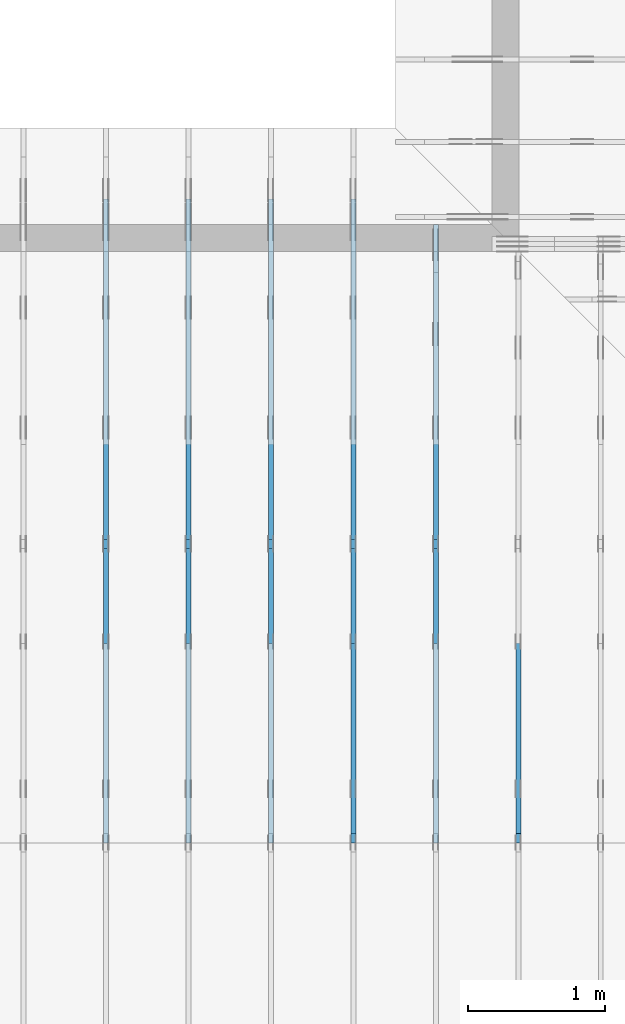
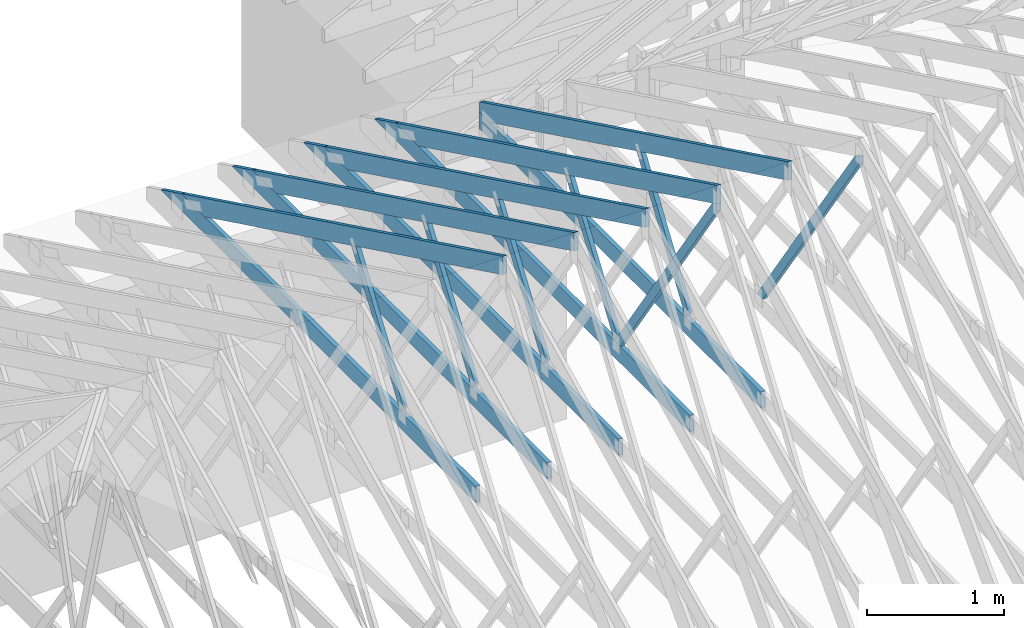
# One storey, part 16 of 159: 17 members, 6 elements without a shape of their own.
"""IFC2X3 building model written with IfcOpenShell, lengths in millimetres."""

from ifc_helpers import new_model, si_unit, frame, origin, origin_with_axes, origin_2d, place, context, project, spatial, faceted_brep, element, aggregate, save


model = new_model("IFC2X3")

# Units and contexts
model_context = context("Model", 3, precision=1e-05, world=origin())
plan_context = context("Plan", 2, precision=1e-05, world=origin_2d())
ifc_project = project(units=[si_unit("LENGTHUNIT", "METRE", prefix="MILLI"), si_unit("AREAUNIT", "SQUARE_METRE"), si_unit("VOLUMEUNIT", "CUBIC_METRE"), si_unit("SOLIDANGLEUNIT", "STERADIAN"), si_unit("PLANEANGLEUNIT", "RADIAN"), si_unit("MASSUNIT", "GRAM"), si_unit("TIMEUNIT", "SECOND"), si_unit("THERMODYNAMICTEMPERATUREUNIT", "DEGREE_CELSIUS"), si_unit("LUMINOUSINTENSITYUNIT", "LUMEN")], contexts=[model_context, plan_context])

# Site, building, storey
site_placement = place(None, origin_with_axes())
site = spatial("IfcSite", under=ifc_project, at=site_placement, CompositionType="ELEMENT")
building_placement = place(site_placement, origin_with_axes())
building = spatial("IfcBuilding", under=site, at=building_placement, Name="Plan 1", CompositionType="ELEMENT")
storey_placement = place(building_placement, origin_with_axes())
storey = spatial("IfcBuildingStorey", under=building, at=storey_placement, Name="Etasje 1", CompositionType="ELEMENT", Elevation=0.0)

# Assembly, member
assembly_1_placement = place(storey_placement, frame((10875.02226140475, -699.9989301294845, 1.1021457184401395e-15), z_axis=(-1.0, 1.836909530733566e-16, 6.123031769111886e-17), x_axis=(-1.836909530733566e-16, -1.0, 0.0)))
assembly_1 = element("IfcElementAssembly", 1, at=assembly_1_placement, inside=storey, Name="T4 (96)", AssemblyPlace="FACTORY", PredefinedType="TRUSS")
member_1_placement = place(assembly_1_placement, frame((-5230.134196319675, 2512.1392759871583, -36.0), z_axis=(0.0, 0.0, 1.0), x_axis=(-0.5642475050074617, -0.8256056886267528, 0.0)))
member_1 = element("IfcMember", 2, at=member_1_placement, Name="T4-D10", context=model_context, shape_type="Brep", body=[
    faceted_brep([(2543.5256108538483, 72.99999048793325, 36.0), (53.406771110820955, 72.99999048793325, 36.0), (0.0, 36.50009322373626, 36.0), (64.12142578860312, 0.00011835360965051223, 36.0), (2593.4163311647717, 0.00011835360965051223, 36.0), (53.406771110820955, 72.99999048793325, 6.5402271239448724e-15), (2543.5256108538483, 72.99999048793325, 3.114817624161566e-13), (2593.4163311647717, 0.00011835360965051223, 3.175914117251098e-13), (64.12142578860312, 0.00011835360965051223, 7.852350543687342e-15), (0.0, 36.50009322373626, 0.0), (3.72532881449672e-05, 36.50017519275116, 3.944304526105059e-31), (3.72532881449672e-05, 36.50017519275116, 36.0), (53.40675570041866, 73.00017519218363, 36.0), (53.40675570041866, 73.00017519218363, 7.888609052210118e-31), (64.12144158709383, 0.00017519218362238576, 7.888609052210118e-31), (64.12144158709383, 0.00017519218362593847, 36.0), (3.7253288159178055e-05, 36.500175192751165, 36.0), (3.72532881574017e-05, 36.500175192751165, -3.944304526105059e-31), (2593.4162114323694, 0.0001751921831566568, 2.916933296842317e-29), (2593.4162114323694, 0.00017519218315886108, 36.0), (64.12144158709384, 0.00017519218362346966, 36.0), (64.12144158709384, 0.00017519218362126537, 7.212035881277958e-31), (2543.52548462057, 73.00017519218363, -8.473528143218631e-30), (2543.52548462057, 73.00017519218363, 36.0), (2593.41621143237, 0.00017519218386041757, 36.0), (2593.41621143237, 0.00017519218386041757, -9.018458054926462e-30), (53.40675570041867, 73.00017519218363, 0.0), (53.40675570041867, 73.00017519218363, 36.0), (2543.52548462057, 73.00017519218348, 36.0), (2543.52548462057, 73.00017519218348, -9.466330862652142e-30)], [[[0, 1, 2, 3, 4]], [[5, 6, 7, 8, 9]], [[10, 11, 12, 13]], [[14, 15, 16, 17]], [[18, 19, 20, 21]], [[22, 23, 24, 25]], [[26, 27, 28, 29]]]),
])
aggregate(assembly_1, [member_1])

# Assembly, members
assembly_2_placement = place(storey_placement, frame((10275.02226140475, -699.9989301294845, 1.1021457184401395e-15), z_axis=(-1.0, 1.836909530733566e-16, 6.123031769111886e-17), x_axis=(-1.836909530733566e-16, -1.0, 0.0)))
assembly_2 = element("IfcElementAssembly", 3, at=assembly_2_placement, inside=storey, Name="T3 (95)", AssemblyPlace="FACTORY", PredefinedType="TRUSS")
member_2_placement = place(assembly_2_placement, frame((-9670.743129899618, 311.0165290904456, -36.0), z_axis=(0.0, 0.0, 1.0), x_axis=(0.898794046299167, 0.4383711467890774, 0.0)))
member_2 = element("IfcMember", 4, at=member_2_placement, Name="T3-O6", context=model_context, shape_type="Brep", body=[
    faceted_brep([(5046.342559639348, 148.00022876572712, 36.0), (39.63434100887753, 148.00022876572712, 36.0), (0.0, 66.73772613040637, 36.0), (136.8326162634403, 0.00027202273213333683, 36.0), (4974.158157629452, 0.00027202273213333683, 36.0), (39.63434100887753, 148.00016775937365, 4.853646582903423e-15), (5046.342559639348, 148.00016775937365, 6.179783162098624e-13), (4974.158157629452, 0.00027202273213333683, 6.091385684750437e-13), (136.8326162634403, 0.00027202273213333683, 1.6756609128634812e-14), (0.0, 66.73772613040637, 0.0), (39.63443079568788, 148.0001389979634, -1.5777218104420236e-30), (39.63443079568788, 148.0001389979634, 36.0), (5046.342588912216, 148.00018235817603, 36.0), (5046.342588912216, 148.00018235817603, -4.733165431326071e-30), (8.386469560761611e-05, 66.7376852268617, 1.5777218104420236e-30), (8.386469561116883e-05, 66.7376852268617, 36.0), (39.63443079568785, 148.00013899796346, 36.0), (39.63443079568785, 148.00013899796346, 2.7610131682735413e-30), (136.8323349366292, 0.00013721225329987874, 1.5777218104420236e-30), (136.8323349366292, 0.00013721225329987874, 36.0), (8.386469562537968e-05, 66.73768522686169, 36.0), (8.386469562537968e-05, 66.73768522686169, 0.0), (4974.158165804005, 0.00018235721913755211, 2.310725526200097e-28), (4974.158165804005, 0.0001823572191397564, 36.0), (136.8323349366292, 0.00013721225321958647, 36.0), (136.8323349366292, 0.00013721225321738218, 6.356494165630846e-30), (5046.342588912216, 148.00018235817538, 1.082008787315909e-28), (5046.342588912216, 148.00018235817538, 36.0), (4974.158165804005, 0.00018235722245663055, 36.0), (4974.158165804005, 0.00018235722245663055, 1.0769346525604365e-28)], [[[0, 1, 2, 3, 4]], [[5, 6, 7, 8, 9]], [[10, 11, 12, 13]], [[14, 15, 16, 17]], [[18, 19, 20, 21]], [[22, 23, 24, 25]], [[26, 27, 28, 29]]]),
])
member_3_placement = place(assembly_2_placement, frame((-5591.18115234375, 371.0000000000005, -36.0), z_axis=(0.0, 0.0, 1.0), x_axis=(-1.0, 1.2246063538223773e-16, 0.0)))
member_3 = element("IfcMember", 5, at=member_3_placement, Name="T3-U36", context=model_context, shape_type="Brep", body=[
    faceted_brep([(4108.81787109375, 148.00000000000102, 36.0), (0.0, 148.00000000000102, 36.0), (0.0, 5.115907697472721e-13, 36.0), (4108.81787109375, 5.115907697472721e-13, 36.0), (0.0, 148.00000000000102, 0.0), (4108.81787109375, 148.00000000000102, 5.03168447164034e-13), (4108.81787109375, 5.115907697472721e-13, 5.03168447164034e-13), (0.0, 5.115907697472721e-13, 0.0), (0.00014333892431750428, 0.0, 0.0), (0.00014333892431970857, -2.6993892992798474e-31, 36.0), (0.00014333892433783274, 147.99999999999997, 36.0), (0.00014333892433562845, 147.99999999999997, -1.1097494219785373e-30), (4108.817777785727, -7.547526893006019e-13, 1.088634776630412e-28), (4108.817777785727, -7.525483978637216e-13, 36.0), (0.00014333892431750428, 2.2042294124261307e-15, 36.0), (0.00014333892431750428, -6.202445414848912e-20, 3.797777032130224e-36), (4108.817777785727, 148.00000000000102, 0.0), (4108.817777785727, 148.00000000000102, 36.0), (4108.817777785727, 1.0231815394945443e-12, 36.0), (4108.817777785727, 1.0231815394945443e-12, 0.0), (0.00014333892431750428, 147.99999999999997, 0.0), (0.00014333892431750428, 147.99999999999997, 36.0), (4108.817777785727, 148.00000000000063, 36.0), (4108.817777785727, 148.00000000000063, -2.3665827156630354e-29)], [[[0, 1, 2, 3]], [[4, 5, 6, 7]], [[8, 9, 10, 11]], [[12, 13, 14, 15]], [[16, 17, 18, 19]], [[20, 21, 22, 23]]]),
])
member_4_placement = place(assembly_2_placement, frame((-7407.03675845016, 1415.1000747842745, -36.0), z_axis=(0.0, 0.0, 1.0), x_axis=(0.5642475146587648, -0.825605682030718, 0.0)))
member_4 = element("IfcMember", 6, at=member_4_placement, Name="T3-D42", context=model_context, shape_type="Brep", body=[
    faceted_brep([(1236.1861515968458, 73.00016783019692, 36.0), (10.714714150930376, 73.00016783019692, 36.0), (5.8619780247681774e-05, 0.00012630768742383225, 36.0), (1264.6475113078654, 0.00012630768742383225, 36.0), (10.714714150930376, 73.00016783019692, 1.3121307028619877e-15), (1236.1861515968458, 73.00016783019692, 1.5138414157527298e-13), (1264.6475113078654, 0.00012630768742383225, 1.5486953776932687e-13), (5.8619780247681774e-05, 0.00012630768742383225, 7.178615535098259e-21), (-5.169199835945012e-16, 1.8190652752628798e-12, 3.199029423154123e-32), (1.6640044277278812e-15, 1.8187451667643957e-12, 36.0), (10.71468606065991, 73.00000000000276, 36.0), (10.714686060659908, 73.00000000000276, 6.262642696661222e-31), (1264.6473946450233, -6.597799305856201e-13, 4.039853475598186e-29), (1264.6473946450233, -6.575756391487398e-13, 36.0), (4.320516564825666e-30, 1.8211936949827368e-12, 36.0), (0.0, 1.8189894035458565e-12, 0.0), (1236.1860387301315, 73.00000000000097, 1.262177448353619e-29), (1236.1860387301315, 73.00000000000097, 36.0), (1264.6473946450235, 5.684341886080802e-14, 36.0), (1264.6473946450235, 5.684341886080802e-14, 1.262177448353619e-29), (10.714686060659915, 73.00000000000273, 0.0), (10.714686060659915, 73.00000000000273, 36.0), (1236.1860387301313, 73.0000000000013, 36.0), (1236.1860387301313, 73.0000000000013, 2.3665827156630354e-29)], [[[0, 1, 2, 3]], [[4, 5, 6, 7]], [[8, 9, 10, 11]], [[12, 13, 14, 15]], [[16, 17, 18, 19]], [[20, 21, 22, 23]]]),
])
aggregate(assembly_2, [member_2, member_3, member_4])

assembly_3_placement = place(storey_placement, frame((9675.022261404752, 9699.99999999999, 1.1021457184401395e-15), z_axis=(-1.0, 1.836909530733566e-16, 6.123031769111886e-17), x_axis=(-1.836909530733566e-16, -1.0, 0.0)))
assembly_3 = element("IfcElementAssembly", 7, at=assembly_3_placement, inside=storey, Name="T2 (94)", AssemblyPlace="FACTORY", PredefinedType="TRUSS")
member_5_placement = place(assembly_3_placement, frame((579.5051980003889, 237.97847286708455, -36.00000000000001), z_axis=(0.0, 0.0, 1.0), x_axis=(0.8987940462991671, 0.43837114678907757, 0.0)))
member_5 = element("IfcMember", 8, at=member_5_placement, Name="T2-O3", context=model_context, shape_type="Brep", body=[
    faceted_brep([(5212.955369683486, 148.00001471731446, 36.0), (1.573016606926103e-05, 148.00001471731446, 36.0), (303.44498744329735, 0.0, 36.0), (5140.770967673589, 0.0, 36.0), (1.573016606926103e-05, 148.00001471731446, 1.9263261315098228e-21), (5212.955369683486, 148.00001471731446, 6.383818267906877e-13), (5140.770967673589, 0.0, 6.295420790558688e-13), (303.44498744329735, 0.0, 3.716006596586134e-14), (303.44496855236554, 9.213724169399029e-06, 8.404281481000962e-31), (303.44496855236554, 9.213724169399029e-06, 36.0), (0.0, 148.000009213056, 36.0), (0.0, 148.000009213056, -1.9992365007213114e-31), (5140.770891984262, 9.214032787493993e-06, -1.5668329852774188e-28), (5140.770891984262, 9.214032789698284e-06, 36.0), (303.4449685523656, 9.213724336859708e-06, 36.0), (303.4449685523656, 9.213724334655416e-06, -9.24856583218491e-30), (5212.955315091657, 148.00000921330889, -5.793884668474286e-29), (5212.955315091657, 148.00000921330889, 36.0), (5140.770891984262, 9.214030342263868e-06, 36.0), (5140.770891984262, 9.214030342263868e-06, -5.743143320920135e-29), (0.0, 148.000009213056, 0.0), (0.0, 148.000009213056, 36.0), (5212.955315091657, 148.00000921330917, 36.0), (5212.955315091657, 148.00000921330917, 9.466330862652142e-30)], [[[0, 1, 2, 3]], [[4, 5, 6, 7]], [[8, 9, 10, 11]], [[12, 13, 14, 15]], [[16, 17, 18, 19]], [[20, 21, 22, 23]]]),
])
member_6_placement = place(assembly_3_placement, frame((4808.81787109375, 371.0000000000005, -36.0), z_axis=(0.0, 0.0, 1.0), x_axis=(-1.0, 1.2246063538223773e-16, 0.0)))
member_6 = element("IfcMember", 9, at=member_6_placement, Name="T2-U35", context=model_context, shape_type="Brep", body=[
    faceted_brep([(4597.636581420898, 148.00000000000105, 36.0), (0.0, 148.00000000000105, 36.0), (0.0, 5.115907697472721e-13, 36.0), (4294.191589355469, 5.115907697472721e-13, 36.0), (0.0, 148.00000000000105, 0.0), (4597.636581420898, 148.00000000000105, 5.630294970174226e-13), (4294.191589355469, 5.115907697472721e-13, 5.25869430485532e-13), (0.0, 5.115907697472721e-13, 0.0), (0.00023664694708713796, 0.0, 0.0), (0.00023664694708934225, -2.6993892992798474e-31, 36.0), (0.00023664694710746643, 147.99999999999994, 36.0), (0.00023664694710526213, 147.99999999999994, -1.1097479173457682e-30), (4294.191606856883, -7.888042053292689e-13, 1.1094846280734072e-28), (4294.191606856883, -7.865999138923886e-13, 36.0), (0.00023664694708713796, 2.2041915808575547e-15, 36.0), (0.00023664694708713796, -9.985602272457245e-20, 6.114215994797155e-36), (4597.636575412006, 148.00000000000205, -2.5243548967072372e-29), (4597.636575412006, 148.00000000000205, 36.0), (4294.191606856883, 1.5916157281026244e-12, 36.0), (4294.191606856883, 1.5916157281026244e-12, -2.5243548967072372e-29), (0.00023664694708713796, 147.99999999999994, 0.0), (0.00023664694708713796, 147.99999999999994, 36.0), (4597.636575412005, 148.00000000000068, 36.0), (4597.636575412005, 148.00000000000068, -2.208810534618833e-29)], [[[0, 1, 2, 3]], [[4, 5, 6, 7]], [[8, 9, 10, 11]], [[12, 13, 14, 15]], [[16, 17, 18, 19]], [[20, 21, 22, 23]]]),
])
member_7_placement = place(assembly_3_placement, frame((5169.864827117615, 2512.139275987297, -36.0), z_axis=(0.0, 0.0, 1.0), x_axis=(-0.564247505007381, -0.8256056886268078, 0.0)))
member_7 = element("IfcMember", 10, at=member_7_placement, Name="T2-D10", context=model_context, shape_type="Brep", body=[
    faceted_brep([(2543.525473098112, 73.00019205182707, 36.0), (53.406771110823684, 73.00019205182707, 36.0), (0.0, 36.5000932239891, 36.0), (64.12142578859857, 0.00011835385657832376, 36.0), (2593.4163311647667, 0.00011835385657832376, 36.0), (53.406771110823684, 73.00019205182707, 6.540227123945206e-15), (2543.525473098112, 73.00019205182707, 3.114817455465016e-13), (2593.4163311647667, 0.00011835385657832376, 3.175914117251092e-13), (64.12142578859857, 0.00011835385657832376, 7.852350543686785e-15), (0.0, 36.5000932239891, 0.0), (8.990056994662154e-05, 36.50009815631665, 3.944304526105059e-31), (8.990056994662154e-05, 36.50009815631665, 36.0), (53.40680834923387, 73.00009815680099, 36.0), (53.40680834923387, 73.00009815680099, 7.888609052210118e-31), (64.12149423256596, 9.815680185809583e-05, 6.171430365172586e-31), (64.12149423256596, 9.815680186164855e-05, 36.0), (8.990056995195062e-05, 36.50009815631667, 36.0), (8.990056995017426e-05, 36.50009815631666, -3.3878954237129854e-31), (2593.4162640810096, 9.815680364966906e-05, 2.3313020864942917e-30), (2593.4162640810096, 9.815680365187335e-05, 36.0), (64.12149423256596, 9.815680187001689e-05, 36.0), (64.12149423256596, 9.81568018678126e-05, 5.76409767496333e-32), (2543.5255372692222, 73.00009815680278, 0.0), (2543.5255372692222, 73.00009815680278, 36.0), (2593.4162640810096, 9.815680414249073e-05, 36.0), (2593.4162640810096, 9.815680414249073e-05, 0.0), (53.40680834923387, 73.00009815680097, 7.888609052210118e-31), (53.40680834923387, 73.00009815680097, 36.0), (2543.525537269222, 73.00009815680359, 36.0), (2543.525537269222, 73.00009815680359, 4.9698237028923744e-29)], [[[0, 1, 2, 3, 4]], [[5, 6, 7, 8, 9]], [[10, 11, 12, 13]], [[14, 15, 16, 17]], [[18, 19, 20, 21]], [[22, 23, 24, 25]], [[26, 27, 28, 29]]]),
])
member_8_placement = place(assembly_3_placement, frame((2992.962039007774, 1415.1000197155186, -36.0), z_axis=(0.0, 0.0, 1.0), x_axis=(0.5642475050068997, -0.8256056886271368, 0.0)))
member_8 = element("IfcMember", 11, at=member_8_placement, Name="T2-D42", context=model_context, shape_type="Brep", body=[
    faceted_brep([(1236.1860950310158, 73.0001983605489, 36.0), (10.714657585100667, 73.0001983605489, 36.0), (2.9073682981106685e-06, 0.00014238622361517628, 36.0), (1264.647317839714, 0.00014238622361517628, 36.0), (10.714657585100667, 73.0001983605489, 1.3121237757745405e-15), (1236.1860950310158, 73.0001983605489, 1.513841346481855e-13), (1264.647317839714, 0.00014238622361517628, 1.5486951407709413e-13), (2.9073682981106685e-06, 0.00014238622361517628, 3.560381690768076e-22), (-1.0876495965808294e-15, 9.815680186891362e-05, 6.73106873190455e-32), (1.0932755894164925e-15, 9.815680186859351e-05, 36.0), (10.71468588481117, 73.00009815680141, 36.0), (10.714685884811168, 73.00009815680141, -5.004528960490232e-31), (1264.6473849234712, 9.81568027596822e-05, 5.682548008281813e-29), (1264.6473849234712, 9.815680276188649e-05, 36.0), (-1.5529013882837331e-30, 9.815680187095826e-05, 36.0), (0.0, 9.815680186875397e-05, 0.0), (1236.1860298813824, 73.00009815680414, 0.0), (1236.1860298813824, 73.00009815680414, 36.0), (1264.6473849234712, 9.81568037445868e-05, 36.0), (1264.6473849234712, 9.81568037445868e-05, 1.262177448353619e-29), (10.714685884811162, 73.00009815680141, 0.0), (10.714685884811162, 73.0000981568014, 36.0), (1236.1860298813824, 73.00009815680406, 36.0), (1236.1860298813824, 73.00009815680406, -5.5220263365470826e-30)], [[[0, 1, 2, 3]], [[4, 5, 6, 7]], [[8, 9, 10, 11]], [[12, 13, 14, 15]], [[16, 17, 18, 19]], [[20, 21, 22, 23]]]),
])
aggregate(assembly_3, [member_5, member_6, member_7, member_8])

assembly_4_placement = place(storey_placement, frame((9075.022261404752, 9699.99999999999, 1.1021457184401395e-15), z_axis=(-1.0, 1.836909530733566e-16, 6.123031769111886e-17), x_axis=(-1.836909530733566e-16, -1.0, 0.0)))
assembly_4 = element("IfcElementAssembly", 12, at=assembly_4_placement, inside=storey, Name="T2 (93)", AssemblyPlace="FACTORY", PredefinedType="TRUSS")
member_9_placement = place(assembly_4_placement, frame((579.5051980003889, 237.97847286708455, -36.00000000000001), z_axis=(0.0, 0.0, 1.0), x_axis=(0.8987940462991671, 0.43837114678907757, 0.0)))
member_9 = element("IfcMember", 13, at=member_9_placement, Name="T2-O3", context=model_context, shape_type="Brep", body=[
    faceted_brep([(5212.955369683486, 148.00001471731446, 36.0), (1.573016606926103e-05, 148.00001471731446, 36.0), (303.44498744329735, 0.0, 36.0), (5140.770967673589, 0.0, 36.0), (1.573016606926103e-05, 148.00001471731446, 1.9263261315098228e-21), (5212.955369683486, 148.00001471731446, 6.383818267906877e-13), (5140.770967673589, 0.0, 6.295420790558688e-13), (303.44498744329735, 0.0, 3.716006596586134e-14), (303.44496855236554, 9.213724169399029e-06, 8.404281481000962e-31), (303.44496855236554, 9.213724169399029e-06, 36.0), (0.0, 148.000009213056, 36.0), (0.0, 148.000009213056, -1.9992365007213114e-31), (5140.770891984262, 9.214032787493993e-06, -1.5668329852774188e-28), (5140.770891984262, 9.214032789698284e-06, 36.0), (303.4449685523656, 9.213724336859708e-06, 36.0), (303.4449685523656, 9.213724334655416e-06, -9.24856583218491e-30), (5212.955315091657, 148.00000921330889, -5.793884668474286e-29), (5212.955315091657, 148.00000921330889, 36.0), (5140.770891984262, 9.214030342263868e-06, 36.0), (5140.770891984262, 9.214030342263868e-06, -5.743143320920135e-29), (0.0, 148.000009213056, 0.0), (0.0, 148.000009213056, 36.0), (5212.955315091657, 148.00000921330917, 36.0), (5212.955315091657, 148.00000921330917, 9.466330862652142e-30)], [[[0, 1, 2, 3]], [[4, 5, 6, 7]], [[8, 9, 10, 11]], [[12, 13, 14, 15]], [[16, 17, 18, 19]], [[20, 21, 22, 23]]]),
])
member_10_placement = place(assembly_4_placement, frame((4808.81787109375, 371.0000000000005, -36.0), z_axis=(0.0, 0.0, 1.0), x_axis=(-1.0, 1.2246063538223773e-16, 0.0)))
member_10 = element("IfcMember", 14, at=member_10_placement, Name="T2-U35", context=model_context, shape_type="Brep", body=[
    faceted_brep([(4597.636581420898, 148.00000000000105, 36.0), (0.0, 148.00000000000105, 36.0), (0.0, 5.115907697472721e-13, 36.0), (4294.191589355469, 5.115907697472721e-13, 36.0), (0.0, 148.00000000000105, 0.0), (4597.636581420898, 148.00000000000105, 5.630294970174226e-13), (4294.191589355469, 5.115907697472721e-13, 5.25869430485532e-13), (0.0, 5.115907697472721e-13, 0.0), (0.00023664694708713796, 0.0, 0.0), (0.00023664694708934225, -2.6993892992798474e-31, 36.0), (0.00023664694710746643, 147.99999999999994, 36.0), (0.00023664694710526213, 147.99999999999994, -1.1097479173457682e-30), (4294.191606856883, -7.888042053292689e-13, 1.1094846280734072e-28), (4294.191606856883, -7.865999138923886e-13, 36.0), (0.00023664694708713796, 2.2041915808575547e-15, 36.0), (0.00023664694708713796, -9.985602272457245e-20, 6.114215994797155e-36), (4597.636575412006, 148.00000000000205, -2.5243548967072372e-29), (4597.636575412006, 148.00000000000205, 36.0), (4294.191606856883, 1.5916157281026244e-12, 36.0), (4294.191606856883, 1.5916157281026244e-12, -2.5243548967072372e-29), (0.00023664694708713796, 147.99999999999994, 0.0), (0.00023664694708713796, 147.99999999999994, 36.0), (4597.636575412005, 148.00000000000068, 36.0), (4597.636575412005, 148.00000000000068, -2.208810534618833e-29)], [[[0, 1, 2, 3]], [[4, 5, 6, 7]], [[8, 9, 10, 11]], [[12, 13, 14, 15]], [[16, 17, 18, 19]], [[20, 21, 22, 23]]]),
])
member_11_placement = place(assembly_4_placement, frame((2992.962039007774, 1415.1000197155186, -36.0), z_axis=(0.0, 0.0, 1.0), x_axis=(0.5642475050068997, -0.8256056886271368, 0.0)))
member_11 = element("IfcMember", 15, at=member_11_placement, Name="T2-D42", context=model_context, shape_type="Brep", body=[
    faceted_brep([(1236.1860950310158, 73.0001983605489, 36.0), (10.714657585100667, 73.0001983605489, 36.0), (2.9073682981106685e-06, 0.00014238622361517628, 36.0), (1264.647317839714, 0.00014238622361517628, 36.0), (10.714657585100667, 73.0001983605489, 1.3121237757745405e-15), (1236.1860950310158, 73.0001983605489, 1.513841346481855e-13), (1264.647317839714, 0.00014238622361517628, 1.5486951407709413e-13), (2.9073682981106685e-06, 0.00014238622361517628, 3.560381690768076e-22), (-1.0876495965808294e-15, 9.815680186891362e-05, 6.73106873190455e-32), (1.0932755894164925e-15, 9.815680186859351e-05, 36.0), (10.71468588481117, 73.00009815680141, 36.0), (10.714685884811168, 73.00009815680141, -5.004528960490232e-31), (1264.6473849234712, 9.81568027596822e-05, 5.682548008281813e-29), (1264.6473849234712, 9.815680276188649e-05, 36.0), (-1.5529013882837331e-30, 9.815680187095826e-05, 36.0), (0.0, 9.815680186875397e-05, 0.0), (1236.1860298813824, 73.00009815680414, 0.0), (1236.1860298813824, 73.00009815680414, 36.0), (1264.6473849234712, 9.81568037445868e-05, 36.0), (1264.6473849234712, 9.81568037445868e-05, 1.262177448353619e-29), (10.714685884811162, 73.00009815680141, 0.0), (10.714685884811162, 73.0000981568014, 36.0), (1236.1860298813824, 73.00009815680406, 36.0), (1236.1860298813824, 73.00009815680406, -5.5220263365470826e-30)], [[[0, 1, 2, 3]], [[4, 5, 6, 7]], [[8, 9, 10, 11]], [[12, 13, 14, 15]], [[16, 17, 18, 19]], [[20, 21, 22, 23]]]),
])
aggregate(assembly_4, [member_9, member_10, member_11])

assembly_5_placement = place(storey_placement, frame((8475.022261404752, 9699.99999999999, 1.1021457184401395e-15), z_axis=(-1.0, 1.836909530733566e-16, 6.123031769111886e-17), x_axis=(-1.836909530733566e-16, -1.0, 0.0)))
assembly_5 = element("IfcElementAssembly", 16, at=assembly_5_placement, inside=storey, Name="T2 (92)", AssemblyPlace="FACTORY", PredefinedType="TRUSS")
member_12_placement = place(assembly_5_placement, frame((579.5051980003889, 237.97847286708455, -36.00000000000001), z_axis=(0.0, 0.0, 1.0), x_axis=(0.8987940462991671, 0.43837114678907757, 0.0)))
member_12 = element("IfcMember", 17, at=member_12_placement, Name="T2-O3", context=model_context, shape_type="Brep", body=[
    faceted_brep([(5212.955369683486, 148.00001471731446, 36.0), (1.573016606926103e-05, 148.00001471731446, 36.0), (303.44498744329735, 0.0, 36.0), (5140.770967673589, 0.0, 36.0), (1.573016606926103e-05, 148.00001471731446, 1.9263261315098228e-21), (5212.955369683486, 148.00001471731446, 6.383818267906877e-13), (5140.770967673589, 0.0, 6.295420790558688e-13), (303.44498744329735, 0.0, 3.716006596586134e-14), (303.44496855236554, 9.213724169399029e-06, 8.404281481000962e-31), (303.44496855236554, 9.213724169399029e-06, 36.0), (0.0, 148.000009213056, 36.0), (0.0, 148.000009213056, -1.9992365007213114e-31), (5140.770891984262, 9.214032787493993e-06, -1.5668329852774188e-28), (5140.770891984262, 9.214032789698284e-06, 36.0), (303.4449685523656, 9.213724336859708e-06, 36.0), (303.4449685523656, 9.213724334655416e-06, -9.24856583218491e-30), (5212.955315091657, 148.00000921330889, -5.793884668474286e-29), (5212.955315091657, 148.00000921330889, 36.0), (5140.770891984262, 9.214030342263868e-06, 36.0), (5140.770891984262, 9.214030342263868e-06, -5.743143320920135e-29), (0.0, 148.000009213056, 0.0), (0.0, 148.000009213056, 36.0), (5212.955315091657, 148.00000921330917, 36.0), (5212.955315091657, 148.00000921330917, 9.466330862652142e-30)], [[[0, 1, 2, 3]], [[4, 5, 6, 7]], [[8, 9, 10, 11]], [[12, 13, 14, 15]], [[16, 17, 18, 19]], [[20, 21, 22, 23]]]),
])
member_13_placement = place(assembly_5_placement, frame((4808.81787109375, 371.0000000000005, -36.0), z_axis=(0.0, 0.0, 1.0), x_axis=(-1.0, 1.2246063538223773e-16, 0.0)))
member_13 = element("IfcMember", 18, at=member_13_placement, Name="T2-U35", context=model_context, shape_type="Brep", body=[
    faceted_brep([(4597.636581420898, 148.00000000000105, 36.0), (0.0, 148.00000000000105, 36.0), (0.0, 5.115907697472721e-13, 36.0), (4294.191589355469, 5.115907697472721e-13, 36.0), (0.0, 148.00000000000105, 0.0), (4597.636581420898, 148.00000000000105, 5.630294970174226e-13), (4294.191589355469, 5.115907697472721e-13, 5.25869430485532e-13), (0.0, 5.115907697472721e-13, 0.0), (0.00023664694708713796, 0.0, 0.0), (0.00023664694708934225, -2.6993892992798474e-31, 36.0), (0.00023664694710746643, 147.99999999999994, 36.0), (0.00023664694710526213, 147.99999999999994, -1.1097479173457682e-30), (4294.191606856883, -7.888042053292689e-13, 1.1094846280734072e-28), (4294.191606856883, -7.865999138923886e-13, 36.0), (0.00023664694708713796, 2.2041915808575547e-15, 36.0), (0.00023664694708713796, -9.985602272457245e-20, 6.114215994797155e-36), (4597.636575412006, 148.00000000000205, -2.5243548967072372e-29), (4597.636575412006, 148.00000000000205, 36.0), (4294.191606856883, 1.5916157281026244e-12, 36.0), (4294.191606856883, 1.5916157281026244e-12, -2.5243548967072372e-29), (0.00023664694708713796, 147.99999999999994, 0.0), (0.00023664694708713796, 147.99999999999994, 36.0), (4597.636575412005, 148.00000000000068, 36.0), (4597.636575412005, 148.00000000000068, -2.208810534618833e-29)], [[[0, 1, 2, 3]], [[4, 5, 6, 7]], [[8, 9, 10, 11]], [[12, 13, 14, 15]], [[16, 17, 18, 19]], [[20, 21, 22, 23]]]),
])
member_14_placement = place(assembly_5_placement, frame((2992.962039007774, 1415.1000197155186, -36.0), z_axis=(0.0, 0.0, 1.0), x_axis=(0.5642475050068997, -0.8256056886271368, 0.0)))
member_14 = element("IfcMember", 19, at=member_14_placement, Name="T2-D42", context=model_context, shape_type="Brep", body=[
    faceted_brep([(1236.1860950310158, 73.0001983605489, 36.0), (10.714657585100667, 73.0001983605489, 36.0), (2.9073682981106685e-06, 0.00014238622361517628, 36.0), (1264.647317839714, 0.00014238622361517628, 36.0), (10.714657585100667, 73.0001983605489, 1.3121237757745405e-15), (1236.1860950310158, 73.0001983605489, 1.513841346481855e-13), (1264.647317839714, 0.00014238622361517628, 1.5486951407709413e-13), (2.9073682981106685e-06, 0.00014238622361517628, 3.560381690768076e-22), (-1.0876495965808294e-15, 9.815680186891362e-05, 6.73106873190455e-32), (1.0932755894164925e-15, 9.815680186859351e-05, 36.0), (10.71468588481117, 73.00009815680141, 36.0), (10.714685884811168, 73.00009815680141, -5.004528960490232e-31), (1264.6473849234712, 9.81568027596822e-05, 5.682548008281813e-29), (1264.6473849234712, 9.815680276188649e-05, 36.0), (-1.5529013882837331e-30, 9.815680187095826e-05, 36.0), (0.0, 9.815680186875397e-05, 0.0), (1236.1860298813824, 73.00009815680414, 0.0), (1236.1860298813824, 73.00009815680414, 36.0), (1264.6473849234712, 9.81568037445868e-05, 36.0), (1264.6473849234712, 9.81568037445868e-05, 1.262177448353619e-29), (10.714685884811162, 73.00009815680141, 0.0), (10.714685884811162, 73.0000981568014, 36.0), (1236.1860298813824, 73.00009815680406, 36.0), (1236.1860298813824, 73.00009815680406, -5.5220263365470826e-30)], [[[0, 1, 2, 3]], [[4, 5, 6, 7]], [[8, 9, 10, 11]], [[12, 13, 14, 15]], [[16, 17, 18, 19]], [[20, 21, 22, 23]]]),
])
aggregate(assembly_5, [member_12, member_13, member_14])

assembly_6_placement = place(storey_placement, frame((7875.0222614047525, 9699.99999999999, 1.1021457184401395e-15), z_axis=(-1.0, 1.836909530733566e-16, 6.123031769111886e-17), x_axis=(-1.836909530733566e-16, -1.0, 0.0)))
assembly_6 = element("IfcElementAssembly", 20, at=assembly_6_placement, inside=storey, Name="T2 (91)", AssemblyPlace="FACTORY", PredefinedType="TRUSS")
member_15_placement = place(assembly_6_placement, frame((579.5051980003889, 237.97847286708455, -36.00000000000001), z_axis=(0.0, 0.0, 1.0), x_axis=(0.8987940462991671, 0.43837114678907757, 0.0)))
member_15 = element("IfcMember", 21, at=member_15_placement, Name="T2-O3", context=model_context, shape_type="Brep", body=[
    faceted_brep([(5212.955369683486, 148.00001471731446, 36.0), (1.573016606926103e-05, 148.00001471731446, 36.0), (303.44498744329735, 0.0, 36.0), (5140.770967673589, 0.0, 36.0), (1.573016606926103e-05, 148.00001471731446, 1.9263261315098228e-21), (5212.955369683486, 148.00001471731446, 6.383818267906877e-13), (5140.770967673589, 0.0, 6.295420790558688e-13), (303.44498744329735, 0.0, 3.716006596586134e-14), (303.44496855236554, 9.213724169399029e-06, 8.404281481000962e-31), (303.44496855236554, 9.213724169399029e-06, 36.0), (0.0, 148.000009213056, 36.0), (0.0, 148.000009213056, -1.9992365007213114e-31), (5140.770891984262, 9.214032787493993e-06, -1.5668329852774188e-28), (5140.770891984262, 9.214032789698284e-06, 36.0), (303.4449685523656, 9.213724336859708e-06, 36.0), (303.4449685523656, 9.213724334655416e-06, -9.24856583218491e-30), (5212.955315091657, 148.00000921330889, -5.793884668474286e-29), (5212.955315091657, 148.00000921330889, 36.0), (5140.770891984262, 9.214030342263868e-06, 36.0), (5140.770891984262, 9.214030342263868e-06, -5.743143320920135e-29), (0.0, 148.000009213056, 0.0), (0.0, 148.000009213056, 36.0), (5212.955315091657, 148.00000921330917, 36.0), (5212.955315091657, 148.00000921330917, 9.466330862652142e-30)], [[[0, 1, 2, 3]], [[4, 5, 6, 7]], [[8, 9, 10, 11]], [[12, 13, 14, 15]], [[16, 17, 18, 19]], [[20, 21, 22, 23]]]),
])
member_16_placement = place(assembly_6_placement, frame((4808.81787109375, 371.0000000000005, -36.0), z_axis=(0.0, 0.0, 1.0), x_axis=(-1.0, 1.2246063538223773e-16, 0.0)))
member_16 = element("IfcMember", 22, at=member_16_placement, Name="T2-U35", context=model_context, shape_type="Brep", body=[
    faceted_brep([(4597.636581420898, 148.00000000000105, 36.0), (0.0, 148.00000000000105, 36.0), (0.0, 5.115907697472721e-13, 36.0), (4294.191589355469, 5.115907697472721e-13, 36.0), (0.0, 148.00000000000105, 0.0), (4597.636581420898, 148.00000000000105, 5.630294970174226e-13), (4294.191589355469, 5.115907697472721e-13, 5.25869430485532e-13), (0.0, 5.115907697472721e-13, 0.0), (0.00023664694708713796, 0.0, 0.0), (0.00023664694708934225, -2.6993892992798474e-31, 36.0), (0.00023664694710746643, 147.99999999999994, 36.0), (0.00023664694710526213, 147.99999999999994, -1.1097479173457682e-30), (4294.191606856883, -7.888042053292689e-13, 1.1094846280734072e-28), (4294.191606856883, -7.865999138923886e-13, 36.0), (0.00023664694708713796, 2.2041915808575547e-15, 36.0), (0.00023664694708713796, -9.985602272457245e-20, 6.114215994797155e-36), (4597.636575412006, 148.00000000000205, -2.5243548967072372e-29), (4597.636575412006, 148.00000000000205, 36.0), (4294.191606856883, 1.5916157281026244e-12, 36.0), (4294.191606856883, 1.5916157281026244e-12, -2.5243548967072372e-29), (0.00023664694708713796, 147.99999999999994, 0.0), (0.00023664694708713796, 147.99999999999994, 36.0), (4597.636575412005, 148.00000000000068, 36.0), (4597.636575412005, 148.00000000000068, -2.208810534618833e-29)], [[[0, 1, 2, 3]], [[4, 5, 6, 7]], [[8, 9, 10, 11]], [[12, 13, 14, 15]], [[16, 17, 18, 19]], [[20, 21, 22, 23]]]),
])
member_17_placement = place(assembly_6_placement, frame((2992.962039007774, 1415.1000197155186, -36.0), z_axis=(0.0, 0.0, 1.0), x_axis=(0.5642475050068997, -0.8256056886271368, 0.0)))
member_17 = element("IfcMember", 23, at=member_17_placement, Name="T2-D42", context=model_context, shape_type="Brep", body=[
    faceted_brep([(1236.1860950310158, 73.0001983605489, 36.0), (10.714657585100667, 73.0001983605489, 36.0), (2.9073682981106685e-06, 0.00014238622361517628, 36.0), (1264.647317839714, 0.00014238622361517628, 36.0), (10.714657585100667, 73.0001983605489, 1.3121237757745405e-15), (1236.1860950310158, 73.0001983605489, 1.513841346481855e-13), (1264.647317839714, 0.00014238622361517628, 1.5486951407709413e-13), (2.9073682981106685e-06, 0.00014238622361517628, 3.560381690768076e-22), (-1.0876495965808294e-15, 9.815680186891362e-05, 6.73106873190455e-32), (1.0932755894164925e-15, 9.815680186859351e-05, 36.0), (10.71468588481117, 73.00009815680141, 36.0), (10.714685884811168, 73.00009815680141, -5.004528960490232e-31), (1264.6473849234712, 9.81568027596822e-05, 5.682548008281813e-29), (1264.6473849234712, 9.815680276188649e-05, 36.0), (-1.5529013882837331e-30, 9.815680187095826e-05, 36.0), (0.0, 9.815680186875397e-05, 0.0), (1236.1860298813824, 73.00009815680414, 0.0), (1236.1860298813824, 73.00009815680414, 36.0), (1264.6473849234712, 9.81568037445868e-05, 36.0), (1264.6473849234712, 9.81568037445868e-05, 1.262177448353619e-29), (10.714685884811162, 73.00009815680141, 0.0), (10.714685884811162, 73.0000981568014, 36.0), (1236.1860298813824, 73.00009815680406, 36.0), (1236.1860298813824, 73.00009815680406, -5.5220263365470826e-30)], [[[0, 1, 2, 3]], [[4, 5, 6, 7]], [[8, 9, 10, 11]], [[12, 13, 14, 15]], [[16, 17, 18, 19]], [[20, 21, 22, 23]]]),
])
aggregate(assembly_6, [member_15, member_16, member_17])

save(model, "model.ifc")
